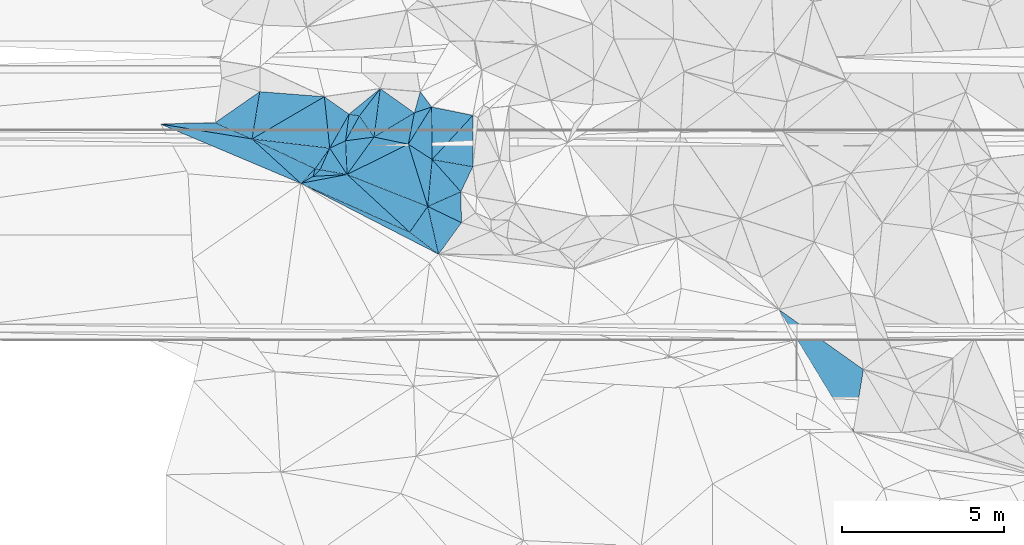
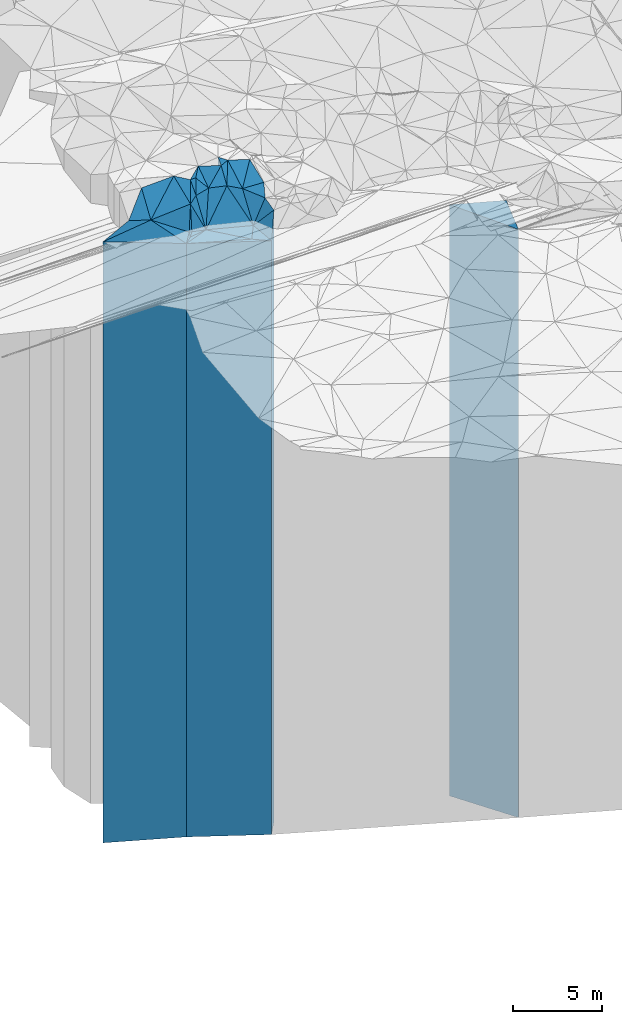
# One storey, part 202 of 275: 40 plates.
"""IFC2X3 building model written with IfcOpenShell, lengths in millimetres."""

from ifc_helpers import new_model, si_unit, frame, origin_with_axes, place, context, subcontext, project, spatial, faceted_brep, material, type_object, element, save


model = new_model("IFC2X3")

# Units and contexts
model_context = context("Model", 3, precision=1e-05, world=origin_with_axes())
body_context = subcontext(model_context, "Body", "Model", "MODEL_VIEW")
ifc_project = project(units=[si_unit("LENGTHUNIT", "METRE", prefix="MILLI"), si_unit("AREAUNIT", "SQUARE_METRE"), si_unit("VOLUMEUNIT", "CUBIC_METRE"), si_unit("MASSUNIT", "GRAM", prefix="KILO"), si_unit("TIMEUNIT", "SECOND"), si_unit("PLANEANGLEUNIT", "RADIAN"), si_unit("SOLIDANGLEUNIT", "STERADIAN"), si_unit("THERMODYNAMICTEMPERATUREUNIT", "DEGREE_CELSIUS"), si_unit("LUMINOUSINTENSITYUNIT", "LUMEN")], contexts=[model_context])

# Site, building, storey
site_placement = place(None, origin_with_axes())
site = spatial("IfcSite", under=ifc_project, at=site_placement, CompositionType="ELEMENT")
building_placement = place(site_placement, origin_with_axes())
building = spatial("IfcBuilding", under=site, at=building_placement, Name="Undefined", CompositionType="ELEMENT")
storey_placement = place(building_placement, origin_with_axes())
storey = spatial("IfcBuildingStorey", under=building, at=storey_placement, Name="Undefined", CompositionType="ELEMENT", Elevation=0.0)

# Plates
ifc_material = material()
plate_type_1 = type_object("IfcPlateType", PredefinedType="NOTDEFINED")
plate_1_placement = place(storey_placement, frame((-132785.212306294, 63386.3738730377, 28121.5), z_axis=(-0.676936122886634, -0.736041768876748, 0.0), x_axis=(-0.73604176887674, 0.676936122886642, 0.0)))
element("IfcPlate", 1, at=plate_1_placement, inside=storey, type_object=plate_type_1, material=ifc_material, Name="00", context=body_context, shape_type="Brep", body=[
    faceted_brep([(0.0, -20328.5, 0.0), (3495.88134765625, -20293.5, 1168.96594238279), (3495.88134765625, 20293.5, 1168.96594238279), (0.0, 20293.5, 0.0), (2628.80200195313, -20568.5, -3.06681613437831e-08), (2628.80200195313, 20293.5, -3.06681613437831e-08)], [[[0, 1, 2, 3]], [[1, 4, 5, 2]], [[4, 0, 3, 5]], [[5, 3, 2]], [[4, 1, 0]]]),
])
plate_type_2 = type_object("IfcPlateType", PredefinedType="NOTDEFINED")
plate_2_placement = place(storey_placement, frame((-132785.212306294, 63386.3738730377, 28121.5), z_axis=(-0.408578737078273, -0.912723077174848, 0.0), x_axis=(-0.912723077174849, 0.408578737078271, 0.0)))
element("IfcPlate", 2, at=plate_2_placement, inside=storey, type_object=plate_type_2, material=ifc_material, Name="00", context=body_context, shape_type="Brep", body=[
    faceted_brep([(0.0, -20328.5, 0.0), (-1094.67358398435, -20325.5, 259.728210449241), (-1094.67358398435, 20293.5, 259.728210449241), (0.0, 20293.5, 0.0), (3686.14550781253, -20293.5, -4.8989022616297e-08), (3686.14550781253, 20293.5, -4.8989022616297e-08)], [[[0, 1, 2, 3]], [[1, 4, 5, 2]], [[4, 0, 3, 5]], [[5, 3, 2]], [[4, 1, 0]]]),
])
plate_type_3 = type_object("IfcPlateType", PredefinedType="NOTDEFINED")
plate_3_placement = place(storey_placement, frame((-131203.971896482, 64632.2385391942, 28269.0), z_axis=(0.404396271985505, -0.914583869967225, 0.0), x_axis=(-0.914583869967225, -0.404396271985505, 0.0)))
element("IfcPlate", 3, at=plate_3_placement, inside=storey, type_object=plate_type_3, material=ifc_material, Name="00", context=body_context, shape_type="Brep", body=[
    faceted_brep([(2.91038304567337e-11, -21701.0, -1.45519152283669e-11), (370.000000000015, -21431.0, 879.999999999985), (370.000000000015, 20441.0, 879.999999999985), (2.91038304567337e-11, 20441.0, -1.45519152283669e-11), (1120.00000000004, -20441.0, 1.25000951811671e-08), (1120.00000000004, 20441.0, 1.25000951811671e-08)], [[[0, 1, 2, 3]], [[1, 4, 5, 2]], [[4, 0, 3, 5]], [[5, 3, 2]], [[4, 1, 0]]]),
])
plate_type_4 = type_object("IfcPlateType", PredefinedType="NOTDEFINED")
plate_4_placement = place(storey_placement, frame((-131186.499208539, 63677.7781129972, 28137.5), z_axis=(-0.433763666082926, -0.901026682172232, 0.0), x_axis=(-0.901026682172237, 0.433763666082915, 0.0)))
element("IfcPlate", 4, at=plate_4_placement, inside=storey, type_object=plate_type_4, material=ifc_material, Name="00", context=body_context, shape_type="Brep", body=[
    faceted_brep([(-2.91038304567337e-11, -21562.5, -1.50066625792533e-11), (212.619491577119, -20309.5, 1185.26025390624), (212.619491577119, 20309.5, 1185.26025390624), (-2.91038304567337e-11, 20309.5, -1.50066625792533e-11), (1156.24389648438, -20572.5, 7.55926521378569e-09), (1156.24389648438, 20309.5, 7.55926521378569e-09)], [[[0, 1, 2, 3]], [[1, 4, 5, 2]], [[4, 0, 3, 5]], [[5, 3, 2]], [[4, 1, 0]]]),
])
plate_type_5 = type_object("IfcPlateType", PredefinedType="NOTDEFINED")
plate_5_placement = place(storey_placement, frame((-132826.744085468, 66101.4935962394, 28259.0), z_axis=(0.443004148760791, -0.896519561515936, 0.0), x_axis=(-0.896519561515932, -0.443004148760801, 0.0)))
element("IfcPlate", 5, at=plate_5_placement, inside=storey, type_object=plate_type_5, material=ifc_material, Name="00", context=body_context, shape_type="Brep", body=[
    faceted_brep([(0.0, -22211.0, 0.0), (315.021606445298, -20451.0, 1988.38159179688), (315.021606445298, 20431.0, 1988.38159179688), (0.0, 20431.0, 0.0), (2111.91845703125, -20431.0, 2.59169610217214e-08), (2111.91845703125, 20431.0, 2.59169610217214e-08)], [[[0, 1, 2, 3]], [[1, 4, 5, 2]], [[4, 0, 3, 5]], [[5, 3, 2]], [[4, 1, 0]]]),
])
plate_type_6 = type_object("IfcPlateType", PredefinedType="NOTDEFINED")
plate_6_placement = place(storey_placement, frame((-132785.212306294, 63386.3738730377, 28137.5), z_axis=(0.608250102936779, 0.793745432917505, 0.0), x_axis=(0.793745432917498, -0.608250102936789, 0.0)))
element("IfcPlate", 6, at=plate_6_placement, inside=storey, type_object=plate_type_6, material=ifc_material, Name="00", context=body_context, shape_type="Brep", body=[
    faceted_brep([(0.0, -20312.5, 1.09139364212751e-11), (-40.264377593965, -20572.5, 968.131591796893), (-40.264377593965, 20309.5, 968.131591796893), (-2.91038304567337e-11, 20309.5, -1.50066625792533e-11), (1125.06396484378, -20309.5, 7.34507921151817e-09), (1125.06396484378, 20309.5, 7.34507921151817e-09)], [[[0, 1, 2, 3]], [[1, 4, 5, 2]], [[4, 0, 3, 5]], [[5, 3, 2]], [[4, 1, 0]]]),
])
plate_type_7 = type_object("IfcPlateType", PredefinedType="NOTDEFINED")
plate_7_placement = place(storey_placement, frame((-135254.674226859, 65979.2020244738, 28299.0), z_axis=(-0.11744179495162, -0.993079767590973, 0.0), x_axis=(-0.993079767590973, 0.117441794951627, 0.0)))
element("IfcPlate", 7, at=plate_7_placement, inside=storey, type_object=plate_type_7, material=ifc_material, Name="00", context=body_context, shape_type="Brep", body=[
    faceted_brep([(0.0, -21851.0, 0.0), (373.107086181641, -20471.0, 685.340148925774), (373.107086181641, 20471.0, 685.340148925774), (0.0, 20471.0, 0.0), (2416.46435546875, -21421.0, -1.67856342159212e-08), (2416.46435546875, 20471.0, -1.67856342159212e-08)], [[[0, 1, 2, 3]], [[1, 4, 5, 2]], [[4, 0, 3, 5]], [[5, 3, 2]], [[4, 1, 0]]]),
])
plate_type_8 = type_object("IfcPlateType", PredefinedType="NOTDEFINED")
plate_8_placement = place(storey_placement, frame((-136149.642290832, 64892.4545080433, 28121.5), z_axis=(-0.489849173934888, 0.871807195884106, 0.0), x_axis=(0.871807195884113, 0.489849173934875, 0.0)))
element("IfcPlate", 8, at=plate_8_placement, inside=storey, type_object=plate_type_8, material=ifc_material, Name="00", context=body_context, shape_type="Brep", body=[
    faceted_brep([(-1.45519152283669e-11, -20293.5, 2.91038304567337e-11), (607.46020507811, -20648.5, 174.814575195342), (607.46020507811, 20293.5, 174.814575195342), (0.0, 20293.5, 0.0), (440.009094238267, -20478.5, 2.91038304567337e-10), (440.009094238267, 20293.5, 2.91038304567337e-10)], [[[0, 1, 2, 3]], [[1, 4, 5, 2]], [[4, 0, 3, 5]], [[5, 3, 2]], [[4, 1, 0]]]),
])
plate_type_9 = type_object("IfcPlateType", PredefinedType="NOTDEFINED")
plate_9_placement = place(storey_placement, frame((-135550.39534303, 65312.6819411678, 28259.0), z_axis=(0.174081986064104, 0.98473116236259, 0.0), x_axis=(0.984731162362591, -0.1740819860641, 0.0)))
element("IfcPlate", 9, at=plate_9_placement, inside=storey, type_object=plate_type_9, material=ifc_material, Name="00", context=body_context, shape_type="Brep", body=[
    faceted_brep([(-2.91038304567337e-11, -20491.0, 0.0), (175.176651000918, -21891.0, 707.822814941406), (175.176651000918, 20431.0, 707.822814941406), (0.0, 20431.0, 0.0), (843.148864746065, -20431.0, 1.07538653537631e-08), (843.148864746065, 20431.0, 1.07538653537631e-08)], [[[0, 1, 2, 3]], [[1, 4, 5, 2]], [[4, 0, 3, 5]], [[5, 3, 2]], [[4, 1, 0]]]),
])
plate_type_10 = type_object("IfcPlateType", PredefinedType="NOTDEFINED")
plate_10_placement = place(storey_placement, frame((-135705.68691062, 65342.4229740281, 28214.0), z_axis=(0.968422957496009, -0.249313006870246, 0.0), x_axis=(-0.249313006870271, -0.968422957496002, 0.0)))
element("IfcPlate", 10, at=plate_10_placement, inside=storey, type_object=plate_type_10, material=ifc_material, Name="00", context=body_context, shape_type="Brep", body=[
    faceted_brep([(-7.27595761418343e-12, -20556.0, 0.0), (-9.91430854798091, -20536.0, 157.802749633818), (-9.91430854798091, 20386.0, 157.802749633818), (-7.27595761418343e-12, 20386.0, 0.0), (242.074371337883, -20386.0, -3.49245965480804e-10), (242.074371337883, 20386.0, -3.49245965480804e-10)], [[[0, 1, 2, 3]], [[1, 4, 5, 2]], [[4, 0, 3, 5]], [[5, 3, 2]], [[4, 1, 0]]]),
])
plate_type_11 = type_object("IfcPlateType", PredefinedType="NOTDEFINED")
plate_11_placement = place(storey_placement, frame((-135550.39534303, 65312.6819411678, 28214.0), z_axis=(0.688444761873534, -0.725288776866768, 0.0), x_axis=(-0.725288776866784, -0.688444761873517, 0.0)))
element("IfcPlate", 11, at=plate_11_placement, inside=storey, type_object=plate_type_11, material=ifc_material, Name="00", context=body_context, shape_type="Brep", body=[
    faceted_brep([(7.27595761418343e-12, -20536.0, 0.0), (-501.141235351541, -20476.0, 678.05419921875), (-501.141235351541, 20386.0, 678.05419921875), (-7.27595761418343e-12, 20386.0, 0.0), (297.321380615242, -20386.0, -3.05590219795704e-09), (297.321380615242, 20386.0, -3.05590219795704e-09)], [[[0, 1, 2, 3]], [[1, 4, 5, 2]], [[4, 0, 3, 5]], [[5, 3, 2]], [[4, 1, 0]]]),
])
plate_type_12 = type_object("IfcPlateType", PredefinedType="NOTDEFINED")
plate_12_placement = place(storey_placement, frame((-132228.305830615, 64179.3147140514, 28139.0), z_axis=(-0.36812810894372, -0.929775077857823, 0.0), x_axis=(-0.929775077857827, 0.368128108943709, 0.0)))
element("IfcPlate", 12, at=plate_12_placement, inside=storey, type_object=plate_type_12, material=ifc_material, Name="00", context=body_context, shape_type="Brep", body=[
    faceted_brep([(2.91038304567337e-11, -20571.0, 3.63797880709171e-12), (225.893951416016, -20311.0, 942.269531250004), (225.893951416016, 20311.0, 942.269531250004), (2.91038304567337e-11, 20311.0, 3.63797880709171e-12), (2680.0185546875, -20551.0, 2.02380761038512e-08), (2680.0185546875, 20311.0, 2.02380761038512e-08)], [[[0, 1, 2, 3]], [[1, 4, 5, 2]], [[4, 0, 3, 5]], [[5, 3, 2]], [[4, 1, 0]]]),
])
plate_type_13 = type_object("IfcPlateType", PredefinedType="NOTDEFINED")
plate_13_placement = place(storey_placement, frame((-132109.751318395, 67249.5011624015, 29069.0), z_axis=(0.848168258978577, -0.529726914986628, 0.0), x_axis=(-0.529726914986621, -0.848168258978581, 0.0)))
element("IfcPlate", 13, at=plate_13_placement, inside=storey, type_object=plate_type_13, material=ifc_material, Name="00", context=body_context, shape_type="Brep", body=[
    faceted_brep([(0.0, -22211.0, 0.0), (1366.22155761718, -21241.0, 873.578002929688), (1366.22155761718, 21241.0, 873.578002929688), (-1.45519152283669e-11, 21241.0, 0.0), (1353.51391601563, -21401.0, 1.74622982740402e-10), (1353.51391601563, 21241.0, 1.74622982740402e-10)], [[[0, 1, 2, 3]], [[1, 4, 5, 2]], [[4, 0, 3, 5]], [[5, 3, 2]], [[4, 1, 0]]]),
])
plate_type_14 = type_object("IfcPlateType", PredefinedType="NOTDEFINED")
plate_14_placement = place(storey_placement, frame((-132092.534549094, 65627.9575820883, 28899.0), z_axis=(0.746113423134664, 0.66581886412017, 0.0), x_axis=(0.66581886412017, -0.746113423134665, 0.0)))
element("IfcPlate", 14, at=plate_14_placement, inside=storey, type_object=plate_type_14, material=ifc_material, Name="00", context=body_context, shape_type="Brep", body=[
    faceted_brep([(0.0, -21411.0, -7.27595761418343e-12), (1001.31799316406, -21531.0, 790.608825683586), (1001.31799316406, 21071.0, 790.608825683586), (0.0, 21071.0, 0.0), (1334.54113769531, -21071.0, 9.60426405072212e-09), (1334.54113769531, 21071.0, 9.60426405072212e-09)], [[[0, 1, 2, 3]], [[1, 4, 5, 2]], [[4, 0, 3, 5]], [[5, 3, 2]], [[4, 1, 0]]]),
])
plate_type_15 = type_object("IfcPlateType", PredefinedType="NOTDEFINED")
plate_15_placement = place(storey_placement, frame((-133694.643315546, 67817.0549989382, 29189.0), z_axis=(0.794341420045332, -0.607471570034653, 0.0), x_axis=(-0.607471570034665, -0.794341420045322, 0.0)))
element("IfcPlate", 15, at=plate_15_placement, inside=storey, type_object=plate_type_15, material=ifc_material, Name="00", context=body_context, shape_type="Brep", body=[
    faceted_brep([(0.0, -21901.0, 0.0), (1304.18774414063, -21361.0, 756.03857421875), (1304.18774414063, 21361.0, 756.03857421875), (0.0, 21361.0, 0.0), (1060.66015624998, -21821.0, 4.56930138170719e-09), (1060.66015624998, 21361.0, 4.56930138170719e-09)], [[[0, 1, 2, 3]], [[1, 4, 5, 2]], [[4, 0, 3, 5]], [[5, 3, 2]], [[4, 1, 0]]]),
])
plate_type_16 = type_object("IfcPlateType", PredefinedType="NOTDEFINED")
plate_16_placement = place(storey_placement, frame((-133886.347542501, 66321.8127144347, 29124.0), z_axis=(-0.821758074128351, -0.56983652708901, 0.0), x_axis=(-0.569836527089011, 0.82175807412835, 0.0)))
element("IfcPlate", 16, at=plate_16_placement, inside=storey, type_object=plate_type_16, material=ifc_material, Name="00", context=body_context, shape_type="Brep", body=[
    faceted_brep([(0.0, -21426.0, 0.0), (406.02188110353, -21296.0, 787.493652343765), (406.02188110353, 21296.0, 787.493652343765), (0.0, 21296.0, 0.0), (794.292114257798, -21886.0, 9.64791979640722e-09), (794.292114257798, 21296.0, 9.64791979640722e-09)], [[[0, 1, 2, 3]], [[1, 4, 5, 2]], [[4, 0, 3, 5]], [[5, 3, 2]], [[4, 1, 0]]]),
])
plate_type_17 = type_object("IfcPlateType", PredefinedType="NOTDEFINED")
plate_17_placement = place(storey_placement, frame((-134658.693189352, 67029.966794978, 29124.0), z_axis=(0.991789398227957, -0.127881936029399, 0.0), x_axis=(-0.127881936029403, -0.991789398227956, 0.0)))
element("IfcPlate", 17, at=plate_17_placement, inside=storey, type_object=plate_type_17, material=ifc_material, Name="00", context=body_context, shape_type="Brep", body=[
    faceted_brep([(-7.27595761418343e-12, -21846.0, -2.91038304567337e-11), (14.0953626632618, -21886.0, 324.193328857422), (14.0953626632618, 21296.0, 324.193328857422), (0.0, 21296.0, 0.0), (830.060241699219, -21296.0, 3.55066731572151e-09), (830.060241699219, 21296.0, 3.55066731572151e-09)], [[[0, 1, 2, 3]], [[1, 4, 5, 2]], [[4, 0, 3, 5]], [[5, 3, 2]], [[4, 1, 0]]]),
])
plate_type_18 = type_object("IfcPlateType", PredefinedType="NOTDEFINED")
plate_18_placement = place(storey_placement, frame((-133886.347542501, 66321.8127144347, 29189.0), z_axis=(-0.514713642050979, 0.85736215608494, 0.0), x_axis=(0.857362156084938, 0.514713642050983, 0.0)))
element("IfcPlate", 18, at=plate_18_placement, inside=storey, type_object=plate_type_18, material=ifc_material, Name="00", context=body_context, shape_type="Brep", body=[
    faceted_brep([(-1.45519152283669e-11, -21361.0, -1.45519152283669e-11), (933.981567382798, -21901.0, 1183.29138183594), (933.981567382798, 21361.0, 1183.29138183594), (0.0, 21361.0, 0.0), (1451.20642089842, -22011.0, -1.41590135172009e-08), (1451.20642089842, 21361.0, -1.41590135172009e-08)], [[[0, 1, 2, 3]], [[1, 4, 5, 2]], [[4, 0, 3, 5]], [[5, 3, 2]], [[4, 1, 0]]]),
])
plate_type_19 = type_object("IfcPlateType", PredefinedType="NOTDEFINED")
plate_19_placement = place(storey_placement, frame((-134658.693189352, 67029.966794978, 29399.0), z_axis=(0.170841814937065, 0.985298469636998, 0.0), x_axis=(0.985298469637004, -0.17084181493703, 0.0)))
element("IfcPlate", 19, at=plate_19_placement, inside=storey, type_object=plate_type_19, material=ifc_material, Name="00", context=body_context, shape_type="Brep", body=[
    faceted_brep([(0.0, -21571.0, 0.0), (815.409301757783, -21691.0, 940.216857910149), (815.409301757783, 21571.0, 940.216857910149), (0.0, 21571.0, 0.0), (324.499603271484, -21611.0, -4.14729584008455e-10), (324.499603271484, 21571.0, -4.14729584008455e-10)], [[[0, 1, 2, 3]], [[1, 4, 5, 2]], [[4, 0, 3, 5]], [[5, 3, 2]], [[4, 1, 0]]]),
])
plate_type_20 = type_object("IfcPlateType", PredefinedType="NOTDEFINED")
plate_20_placement = place(storey_placement, frame((-133886.347542501, 66321.8127144347, 29149.0), z_axis=(0.203572033057588, 0.979059971276939, 0.0), x_axis=(0.97905997127694, -0.203572033057585, 0.0)))
element("IfcPlate", 20, at=plate_20_placement, inside=storey, type_object=plate_type_20, material=ifc_material, Name="00", context=body_context, shape_type="Brep", body=[
    faceted_brep([(0.0, -21401.0, 0.0), (1066.09631347656, -22051.0, 984.600708007805), (1066.09631347656, 21321.0, 984.600708007805), (0.0, 21321.0, 0.0), (1082.26611328122, -21321.0, 7.42875272408128e-09), (1082.26611328122, 21321.0, 7.42875272408128e-09)], [[[0, 1, 2, 3]], [[1, 4, 5, 2]], [[4, 0, 3, 5]], [[5, 3, 2]], [[4, 1, 0]]]),
])
plate_type_21 = type_object("IfcPlateType", PredefinedType="NOTDEFINED")
plate_21_placement = place(storey_placement, frame((-132109.751318395, 67249.5011624015, 29514.0), z_axis=(-0.801765162705528, -0.597639208780497, 0.0), x_axis=(-0.597639208780488, 0.801765162705535, 0.0)))
element("IfcPlate", 21, at=plate_21_placement, inside=storey, type_object=plate_type_21, material=ifc_material, Name="00", context=body_context, shape_type="Brep", body=[
    faceted_brep([(0.0, -21766.0, 0.0), (173.27001953125, -21686.0, 534.862121582031), (173.27001953125, 21686.0, 534.862121582031), (0.0, 21686.0, 0.0), (584.636657714844, -21806.0, -1.60071067512035e-09), (584.636657714844, 21686.0, -1.60071067512035e-09)], [[[0, 1, 2, 3]], [[1, 4, 5, 2]], [[4, 0, 3, 5]], [[5, 3, 2]], [[4, 1, 0]]]),
])
plate_type_22 = type_object("IfcPlateType", PredefinedType="NOTDEFINED")
plate_22_placement = place(storey_placement, frame((-132642.138099084, 67068.7684433182, 29149.0), z_axis=(0.982270715981855, -0.187467971996536, 0.0), x_axis=(-0.187467971996525, -0.982270715981857, 0.0)))
element("IfcPlate", 22, at=plate_22_placement, inside=storey, type_object=plate_type_22, material=ifc_material, Name="00", context=body_context, shape_type="Brep", body=[
    faceted_brep([(1.45519152283669e-11, -22051.0, 1.45519152283669e-11), (-277.333923339866, -22131.0, 489.066345214844), (-277.333923339866, 21321.0, 489.066345214844), (0.0, 21321.0, 0.0), (984.733459472634, -21321.0, -3.02679836750031e-09), (984.733459472634, 21321.0, -3.02679836750031e-09)], [[[0, 1, 2, 3]], [[1, 4, 5, 2]], [[4, 0, 3, 5]], [[5, 3, 2]], [[4, 1, 0]]]),
])
plate_type_23 = type_object("IfcPlateType", PredefinedType="NOTDEFINED")
plate_23_placement = place(storey_placement, frame((-134720.120386146, 65165.9049130937, 28259.0), z_axis=(-0.443004148760794, 0.896519561515935, 0.0), x_axis=(0.896519561515933, 0.443004148760798, 0.0)))
element("IfcPlate", 23, at=plate_23_placement, inside=storey, type_object=plate_type_23, material=ifc_material, Name="00", context=body_context, shape_type="Brep", body=[
    faceted_brep([(2.91038304567337e-11, -20431.0, 0.0), (1259.56567382814, -22291.0, 666.929138183608), (1259.56567382814, 20431.0, 666.929138183608), (0.0, 20431.0, 0.0), (2111.91845703128, -22211.0, -2.89874151349068e-08), (2111.91845703125, 20431.0, 2.59169610217214e-08)], [[[0, 1, 2, 3]], [[1, 4, 5, 2]], [[4, 0, 3, 5]], [[5, 3, 2]], [[4, 1, 0]]]),
])
plate_type_24 = type_object("IfcPlateType", PredefinedType="NOTDEFINED")
plate_24_placement = place(storey_placement, frame((-134658.693189352, 67029.966794978, 28989.0), z_axis=(-0.576189032767891, -0.817316461670755, 0.0), x_axis=(-0.81731646167075, 0.576189032767898, 0.0)))
element("IfcPlate", 24, at=plate_24_placement, inside=storey, type_object=plate_type_24, material=ifc_material, Name="00", context=body_context, shape_type="Brep", body=[
    faceted_brep([(7.27595761418343e-12, -21981.0, 0.0), (-118.334022521973, -21161.0, 1202.205078125), (-118.334022521973, 21161.0, 1202.205078125), (0.0, 21161.0, -4.54747350886464e-12), (932.952331542969, -22171.0, -4.76575223729014e-10), (932.952331542969, 21161.0, -4.76575223729014e-10)], [[[0, 1, 2, 3]], [[1, 4, 5, 2]], [[4, 0, 3, 5]], [[5, 3, 2]], [[4, 1, 0]]]),
])
plate_type_25 = type_object("IfcPlateType", PredefinedType="NOTDEFINED")
plate_25_placement = place(storey_placement, frame((-137654.416091077, 66262.9959375878, 28774.0), z_axis=(0.11744179495162, 0.993079767590973, 0.0), x_axis=(0.993079767590973, -0.117441794951626, 0.0)))
element("IfcPlate", 25, at=plate_25_placement, inside=storey, type_object=plate_type_25, material=ifc_material, Name="00", context=body_context, shape_type="Brep", body=[
    faceted_brep([(0.0, -20946.0, 0.0), (2064.54516601563, -22386.0, 1557.77172851563), (2064.54516601563, 20946.0, 1557.77172851563), (0.0, 20946.0, 1.45519152283669e-11), (2416.46435546875, -21376.0, -1.67710823006928e-08), (2416.46435546875, 20946.0, -1.67710823006928e-08)], [[[0, 1, 2, 3]], [[1, 4, 5, 2]], [[4, 0, 3, 5]], [[5, 3, 2]], [[4, 1, 0]]]),
])
plate_type_26 = type_object("IfcPlateType", PredefinedType="NOTDEFINED")
plate_26_placement = place(storey_placement, frame((-131203.971896482, 64632.2385391942, 28269.0), z_axis=(-0.746113423134664, -0.66581886412017, 0.0), x_axis=(-0.66581886412017, 0.746113423134664, 0.0)))
element("IfcPlate", 26, at=plate_26_placement, inside=storey, type_object=plate_type_26, material=ifc_material, Name="00", context=body_context, shape_type="Brep", body=[
    faceted_brep([(2.91038304567337e-11, -21701.0, -1.45519152283669e-11), (344.088317871094, -20441.0, 1065.83447265624), (344.088317871094, 20441.0, 1065.83447265624), (2.91038304567337e-11, 20441.0, -1.45519152283669e-11), (1334.54113769531, -22041.0, 1.5788828022778e-09), (1334.54113769531, 20441.0, 1.5788828022778e-09)], [[[0, 1, 2, 3]], [[1, 4, 5, 2]], [[4, 0, 3, 5]], [[5, 3, 2]], [[4, 1, 0]]]),
])
plate_type_27 = type_object("IfcPlateType", PredefinedType="NOTDEFINED")
plate_27_placement = place(storey_placement, frame((-132092.534549094, 65627.9575820883, 29069.0), z_axis=(0.172983359022153, 0.984924747126101, 0.0), x_axis=(0.984924747126102, -0.172983359022145, 0.0)))
element("IfcPlate", 27, at=plate_27_placement, inside=storey, type_object=plate_type_27, material=ifc_material, Name="00", context=body_context, shape_type="Brep", body=[
    faceted_brep([(5.45696821063757e-12, -21241.0, 0.0), (1000.61651611325, -21971.0, 1560.88647460938), (1000.61651611325, 21241.0, 1560.88647460938), (-1.45519152283669e-11, 21241.0, 0.0), (1275.81347656247, -21361.0, 2.70665623247623e-09), (1275.81347656247, 21241.0, 2.70665623247623e-09)], [[[0, 1, 2, 3]], [[1, 4, 5, 2]], [[4, 0, 3, 5]], [[5, 3, 2]], [[4, 1, 0]]]),
])
plate_type_28 = type_object("IfcPlateType", PredefinedType="NOTDEFINED")
plate_28_placement = place(storey_placement, frame((-135254.674226859, 65979.2020244738, 28989.0), z_axis=(-0.421260784185734, 0.906939552399839, 0.0), x_axis=(0.906939552399842, 0.421260784185728, 0.0)))
element("IfcPlate", 28, at=plate_28_placement, inside=storey, type_object=plate_type_28, material=ifc_material, Name="00", context=body_context, shape_type="Brep", body=[
    faceted_brep([(0.0, -21161.0, 2.72848410531878e-12), (983.164794921904, -21981.0, 701.916687011704), (983.164794921904, 21161.0, 701.916687011704), (0.0, 21161.0, -4.54747350886464e-12), (540.092590332075, -21431.0, 2.47382558882236e-09), (540.092590332075, 21161.0, 2.47382558882236e-09)], [[[0, 1, 2, 3]], [[1, 4, 5, 2]], [[4, 0, 3, 5]], [[5, 3, 2]], [[4, 1, 0]]]),
])
plate_type_29 = type_object("IfcPlateType", PredefinedType="NOTDEFINED")
plate_29_placement = place(storey_placement, frame((-137415.054534406, 67724.6409167767, 28774.0), z_axis=(0.571128472961895, -0.820860686945242, 0.0), x_axis=(-0.82086068694524, -0.571128472961897, 0.0)))
element("IfcPlate", 29, at=plate_29_placement, inside=storey, type_object=plate_type_29, material=ifc_material, Name="00", context=body_context, shape_type="Brep", body=[
    faceted_brep([(0.0, -22176.0, 0.0), (1031.26953125001, -20946.0, 1063.10070800778), (1031.26953125001, 20946.0, 1063.10070800778), (0.0, 20946.0, 1.45519152283669e-11), (1680.74389648439, -21006.0, 5.4424162954092e-09), (1680.74389648439, 20946.0, 5.4424162954092e-09)], [[[0, 1, 2, 3]], [[1, 4, 5, 2]], [[4, 0, 3, 5]], [[5, 3, 2]], [[4, 1, 0]]]),
])
plate_type_30 = type_object("IfcPlateType", PredefinedType="NOTDEFINED")
plate_30_placement = place(storey_placement, frame((-135421.210464797, 67567.5236800124, 28774.0), z_axis=(-0.078557635964395, -0.996909573548015, 0.0), x_axis=(-0.996909573548016, 0.0785576359643805, 0.0)))
element("IfcPlate", 30, at=plate_30_placement, inside=storey, type_object=plate_type_30, material=ifc_material, Name="00", context=body_context, shape_type="Brep", body=[
    faceted_brep([(-1.45519152283669e-11, -22386.0, 0.0), (2123.8234863281, -20946.0, 1475.93151855469), (2123.8234863281, 20946.0, 1475.93151855469), (0.0, 20946.0, 1.45519152283669e-11), (2000.02502441409, -22176.0, -9.83709469437599e-09), (2000.02502441409, 20946.0, -9.83709469437599e-09)], [[[0, 1, 2, 3]], [[1, 4, 5, 2]], [[4, 0, 3, 5]], [[5, 3, 2]], [[4, 1, 0]]]),
])
plate_type_31 = type_object("IfcPlateType", PredefinedType="NOTDEFINED")
plate_31_placement = place(storey_placement, frame((-134720.120386146, 65165.9049130937, 28259.0), z_axis=(-0.811028583717092, 0.58500652679594, 0.0), x_axis=(0.585006526795937, 0.811028583717094, 0.0)))
element("IfcPlate", 31, at=plate_31_placement, inside=storey, type_object=plate_type_31, material=ifc_material, Name="00", context=body_context, shape_type="Brep", body=[
    faceted_brep([(2.91038304567337e-11, -20431.0, 0.0), (817.969299316406, -22161.0, 645.155944824219), (817.969299316406, 20431.0, 645.155944824219), (0.0, 20431.0, 0.0), (1425.23681640624, -22291.0, -6.14090822637081e-09), (1425.23681640624, 20431.0, -6.14090822637081e-09)], [[[0, 1, 2, 3]], [[1, 4, 5, 2]], [[4, 0, 3, 5]], [[5, 3, 2]], [[4, 1, 0]]]),
])
plate_type_32 = type_object("IfcPlateType", PredefinedType="NOTDEFINED")
plate_32_placement = place(storey_placement, frame((-130836.99521211, 66992.2233088755, 29069.0), z_axis=(-0.198134789976475, -0.980174782883634, 0.0), x_axis=(-0.980174782883633, 0.198134789976478, 0.0)))
element("IfcPlate", 32, at=plate_32_placement, inside=storey, type_object=plate_type_32, material=ifc_material, Name="00", context=body_context, shape_type="Brep", body=[
    faceted_brep([(1.45519152283669e-11, -21971.0, -1.45519152283669e-11), (960.339477539092, -21241.0, 1585.98486328125), (960.339477539092, 21241.0, 1585.98486328125), (-1.45519152283669e-11, 21241.0, 0.0), (1298.49914550781, -22211.0, 6.94853952154517e-09), (1298.49914550781, 21241.0, 6.94853952154517e-09)], [[[0, 1, 2, 3]], [[1, 4, 5, 2]], [[4, 0, 3, 5]], [[5, 3, 2]], [[4, 1, 0]]]),
])
plate_type_33 = type_object("IfcPlateType", PredefinedType="NOTDEFINED")
plate_33_placement = place(storey_placement, frame((-118771.346950045, 59140.8965409895, 27942.0), z_axis=(-0.579162662985945, -0.815212002980224, 0.0), x_axis=(-0.815212002980221, 0.579162662985949, 0.0)))
element("IfcPlate", 33, at=plate_33_placement, inside=storey, type_object=plate_type_33, material=ifc_material, Name="00", context=body_context, shape_type="Brep", body=[
    faceted_brep([(0.0, -20838.0, 0.0), (-859.93725585936, -20114.0, 1752.16687011719), (-859.93725585936, 20114.0, 1752.16687011719), (0.0, 20114.0, 0.0), (3201.2138671875, -20332.0, 1.48720573633909e-08), (3201.2138671875, 20114.0, 1.48720573633909e-08)], [[[0, 1, 2, 3]], [[1, 4, 5, 2]], [[4, 0, 3, 5]], [[5, 3, 2]], [[4, 1, 0]]]),
])
plate_type_34 = type_object("IfcPlateType", PredefinedType="NOTDEFINED")
plate_34_placement = place(storey_placement, frame((-135705.68691062, 65342.4229740281, 28121.5), z_axis=(-0.427135194175264, -0.904187771371002, 0.0), x_axis=(-0.904187771371003, 0.427135194175261, 0.0)))
element("IfcPlate", 34, at=plate_34_placement, inside=storey, type_object=plate_type_34, material=ifc_material, Name="00", context=body_context, shape_type="Brep", body=[
    faceted_brep([(-2.91038304567337e-11, -20648.5, -1.50066625792533e-11), (209.221664428682, -20293.5, 596.484924316391), (209.221664428682, 20293.5, 596.484924316391), (0.0, 20293.5, 0.0), (2155.22631835935, -21598.5, -1.74045453604776e-08), (2155.22631835935, 20293.5, -1.74045453604776e-08)], [[[0, 1, 2, 3]], [[1, 4, 5, 2]], [[4, 0, 3, 5]], [[5, 3, 2]], [[4, 1, 0]]]),
])
plate_type_35 = type_object("IfcPlateType", PredefinedType="NOTDEFINED")
plate_35_placement = place(storey_placement, frame((-134720.120386146, 65165.9049130937, 28259.0), z_axis=(-0.999078123275406, -0.0429290530118331, 0.0), x_axis=(-0.0429290530118237, 0.999078123275406, 0.0)))
element("IfcPlate", 35, at=plate_35_placement, inside=storey, type_object=plate_type_35, material=ifc_material, Name="00", context=body_context, shape_type="Brep", body=[
    faceted_brep([(2.91038304567337e-11, -20431.0, 0.0), (835.495239257813, -21891.0, 499.146972656279), (835.495239257813, 20431.0, 499.146972656279), (0.0, 20431.0, 0.0), (1041.77734375, -22161.0, 5.82076609134674e-11), (1041.77734375, 20431.0, 5.82076609134674e-11)], [[[0, 1, 2, 3]], [[1, 4, 5, 2]], [[4, 0, 3, 5]], [[5, 3, 2]], [[4, 1, 0]]]),
])
plate_type_36 = type_object("IfcPlateType", PredefinedType="NOTDEFINED")
plate_36_placement = place(storey_placement, frame((-137654.416091077, 66262.9959375878, 28121.5), z_axis=(-0.160328454934041, -0.987063719593859, 0.0), x_axis=(-0.98706371959386, 0.160328454934032, 0.0)))
element("IfcPlate", 36, at=plate_36_placement, inside=storey, type_object=plate_type_36, material=ifc_material, Name="00", context=body_context, shape_type="Brep", body=[
    faceted_brep([(0.0, -21598.5, 0.0), (-1705.04443359372, -20293.5, 1111.55371093749), (-1705.04443359372, 20293.5, 1111.55371093749), (0.0, 20293.5, 0.0), (2861.86083984375, -20824.5, 2.66445567831397e-08), (2861.86083984375, 20293.5, 2.66445567831397e-08)], [[[0, 1, 2, 3]], [[1, 4, 5, 2]], [[4, 0, 3, 5]], [[5, 3, 2]], [[4, 1, 0]]]),
])
plate_type_37 = type_object("IfcPlateType", PredefinedType="NOTDEFINED")
plate_37_placement = place(storey_placement, frame((-135705.68691062, 65342.4229740281, 28289.0), z_axis=(0.188098807986449, 0.98215010992927, 0.0), x_axis=(0.982150109929266, -0.188098807986467, 0.0)))
element("IfcPlate", 37, at=plate_37_placement, inside=storey, type_object=plate_type_37, material=ifc_material, Name="00", context=body_context, shape_type="Brep", body=[
    faceted_brep([(-2.91038304567337e-11, -20481.0, -1.45519152283669e-11), (323.184783935547, -21861.0, 710.247558593743), (323.184783935547, 20461.0, 710.247558593743), (-2.91038304567337e-11, 20461.0, -1.45519152283669e-11), (158.113876342773, -20461.0, -2.13913153856993e-09), (158.113876342773, 20461.0, -2.13913153856993e-09)], [[[0, 1, 2, 3]], [[1, 4, 5, 2]], [[4, 0, 3, 5]], [[5, 3, 2]], [[4, 1, 0]]]),
])
plate_type_38 = type_object("IfcPlateType", PredefinedType="NOTDEFINED")
plate_38_placement = place(storey_placement, frame((-132228.305830615, 64179.3147140514, 28269.0), z_axis=(-0.995636715861805, 0.0933141469870445, 0.0), x_axis=(0.0933141469870454, 0.995636715861805, 0.0)))
element("IfcPlate", 38, at=plate_38_placement, inside=storey, type_object=plate_type_38, material=ifc_material, Name="00", context=body_context, shape_type="Brep", body=[
    faceted_brep([(0.0, -20441.0, 0.0), (1857.94909667969, -22201.0, 775.193603515654), (1857.94909667969, 20441.0, 775.193603515654), (2.91038304567337e-11, 20441.0, -1.45519152283669e-11), (1454.99145507813, -22041.0, -2.96859070658684e-09), (1454.99145507813, 20441.0, -2.96859070658684e-09)], [[[0, 1, 2, 3]], [[1, 4, 5, 2]], [[4, 0, 3, 5]], [[5, 3, 2]], [[4, 1, 0]]]),
])
plate_type_39 = type_object("IfcPlateType", PredefinedType="NOTDEFINED")
plate_39_placement = place(storey_placement, frame((-134720.120386146, 65165.9049130937, 28121.5), z_axis=(0.0552851180190132, -0.998470608343392, 0.0), x_axis=(-0.998470608343392, -0.0552851180190132, 0.0)))
element("IfcPlate", 39, at=plate_39_placement, inside=storey, type_object=plate_type_39, material=ifc_material, Name="00", context=body_context, shape_type="Brep", body=[
    faceted_brep([(2.91038304567337e-11, -20568.5, -1.45519152283669e-11), (1442.45336914064, -20293.5, 194.00090026854), (1442.45336914064, 20293.5, 194.00090026854), (0.0, 20293.5, 0.0), (1047.52087402348, -20478.5, 2.51748133450747e-09), (1047.52087402348, 20293.5, 2.51748133450747e-09)], [[[0, 1, 2, 3]], [[1, 4, 5, 2]], [[4, 0, 3, 5]], [[5, 3, 2]], [[4, 1, 0]]]),
])
plate_type_40 = type_object("IfcPlateType", PredefinedType="NOTDEFINED")
plate_40_placement = place(storey_placement, frame((-140479.255188332, 66721.8336808243, 28387.0), z_axis=(0.16032845493404, 0.987063719593859, 0.0), x_axis=(0.98706371959386, -0.160328454934034, 0.0)))
element("IfcPlate", 40, at=plate_40_placement, inside=storey, type_object=plate_type_40, material=ifc_material, Name="00", context=body_context, shape_type="Brep", body=[
    faceted_brep([(0.0, -20559.0, 1.45519152283669e-11), (1655.87646484372, -21393.0, 312.412109375015), (1655.87646484372, 20559.0, 312.412109375015), (0.0, 20559.0, 1.45519152283669e-11), (2861.86083984375, -21333.0, 2.66736606135964e-08), (2861.86083984375, 20559.0, 2.66736606135964e-08)], [[[0, 1, 2, 3]], [[1, 4, 5, 2]], [[4, 0, 3, 5]], [[5, 3, 2]], [[4, 1, 0]]]),
])

save(model, "model.ifc")
